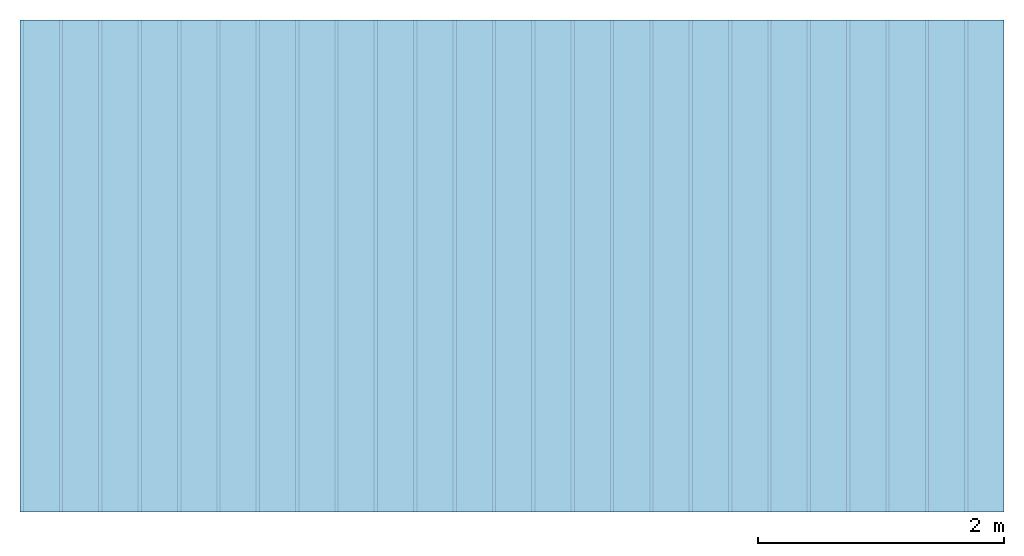
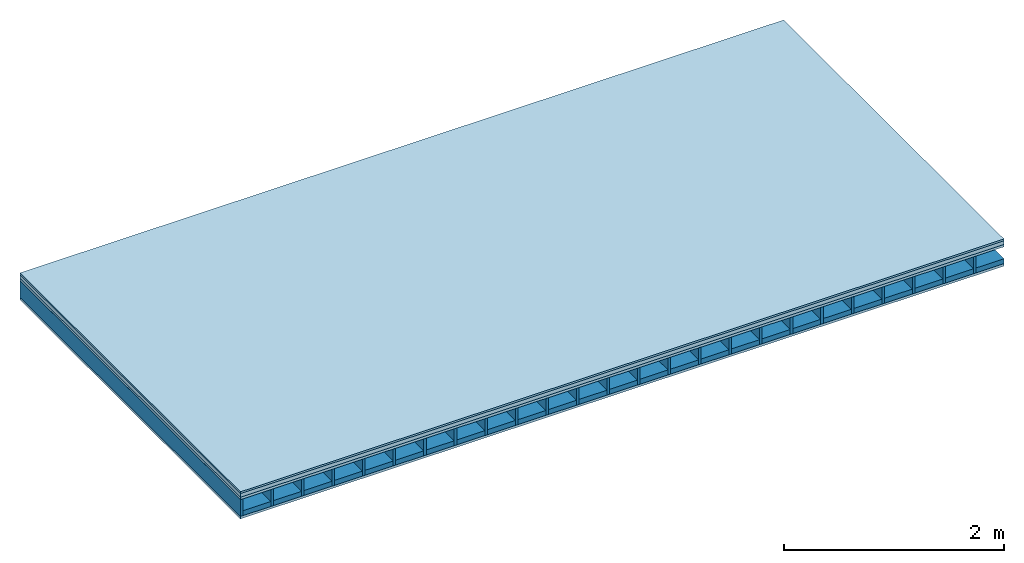
# One storey: 4 plates, 2 members, 1 element without a shape of its own.
"""IFC4 building model written with IfcOpenShell, lengths in metres."""

from ifc_helpers import new_model, si_unit, derived_unit, direction, frame, frame_2d, origin, origin_with_axes, place, context, project, spatial, rectangle, extrude, material, layer, layer_set, type_object, element, aggregate, save


model = new_model("IFC4")

# Units and contexts
plan_context = context("Plan", 3, precision=1e-05, world=origin(), true_north=direction((0.0, 1.0)))
model_context = context("Model", 3, precision=1e-05, world=origin(), true_north=direction((0.0, 1.0)))
ifc_project = project(units=[si_unit("LENGTHUNIT", "METRE"), derived_unit("SOUNDPRESSUREUNIT", [(si_unit("PRESSUREUNIT", "PASCAL", prefix="MICRO"), 0)]), si_unit("ENERGYUNIT", "JOULE", prefix="MEGA"), si_unit("MASSUNIT", "GRAM", prefix="KILO"), derived_unit("THERMALTRANSMITTANCEUNIT", [(si_unit("POWERUNIT", "WATT"), 1), (si_unit("AREAUNIT", "SQUARE_METRE"), -1), (si_unit("THERMODYNAMICTEMPERATUREUNIT", "KELVIN"), -1)]), derived_unit("AREADENSITYUNIT", [(si_unit("MASSUNIT", "GRAM", prefix="KILO"), 1), (si_unit("AREAUNIT", "SQUARE_METRE"), -1)]), derived_unit("USERDEFINED", [(si_unit("ENERGYUNIT", "JOULE", prefix="MEGA"), 1), (si_unit("AREAUNIT", "SQUARE_METRE"), -1)])], contexts=[plan_context, model_context])

# Site, building, storey
site = spatial("IfcSite", under=ifc_project)
building_placement = place(None, origin())
building = spatial("IfcBuilding", under=site, at=building_placement)
storey_placement = place(building_placement, origin())
storey = spatial("IfcBuildingStorey", under=building, at=storey_placement)

# Slab, members, plates
ifc_material_1 = material(Category="03.007")
ifc_layer_1 = layer(ifc_material_1, 0.02, Name="On-material")
ifc_material_2 = material(Name="internal", Category="10.009")
ifc_layer_2 = layer(ifc_material_2, 0.04, Name="Impact sound insulation")
ifc_material_3 = material(Name="3-layer board Spruce Nova Top", Category="07.001")
ifc_layer_3 = layer(ifc_material_3, 0.027, Name="Sub-floor")
ifc_material_4 = material(Name="Rigid, of the art")
ifc_layer_4 = layer(ifc_material_4, 0.0, Name="Bond")
ifc_layer_5 = layer(None, 0.186, Name="Supporting structure")
ifc_layer_6 = layer(ifc_material_4, 0.0, Name="Bond")
ifc_layer_7 = layer(ifc_material_3, 0.027, Name="Lower layer 1")
ifc_layer_set = layer_set([ifc_layer_1, ifc_layer_2, ifc_layer_3, ifc_layer_4, ifc_layer_5, ifc_layer_6, ifc_layer_7])
slab_type = type_object("IfcSlabType", Name="A0018", PredefinedType="NOTDEFINED", material=ifc_layer_set)
slab_placement = place(None, frame((0.0, 0.0, 0.0), z_axis=(0.0, 0.0, -1.0), x_axis=(1.0, 0.0, 0.0)))
slab = element("IfcSlab", 1, at=slab_placement, inside=storey, type_object=slab_type, material=ifc_layer_set, Name="Slab #1")
ifc_material_5 = material()
member_1_placement = place(slab_placement, origin())
member_1 = element("IfcMember", 2, at=member_1_placement, material=ifc_material_5, Name="Supporting structure", context=plan_context, shape_type="SweptSolid", body=[
    extrude(rectangle(XDim=0.027, YDim=0.186, at=frame_2d((0.0135, 0.093), x_axis=(1.0, 0.0))), frame((0.0, 4.0, 0.087), z_axis=(0.0, -1.0, 0.0), x_axis=(1.0, 0.0, 0.0)), (0.0, 0.0, 1.0), 4.0),
    extrude(rectangle(XDim=0.027, YDim=0.186, at=frame_2d((0.0135, 0.093), x_axis=(1.0, 0.0))), frame((0.32, 4.0, 0.087), z_axis=(0.0, -1.0, 0.0), x_axis=(1.0, 0.0, 0.0)), (0.0, 0.0, 1.0), 4.0),
    extrude(rectangle(XDim=0.027, YDim=0.186, at=frame_2d((0.0135, 0.093), x_axis=(1.0, 0.0))), frame((0.64, 4.0, 0.087), z_axis=(0.0, -1.0, 0.0), x_axis=(1.0, 0.0, 0.0)), (0.0, 0.0, 1.0), 4.0),
    extrude(rectangle(XDim=0.027, YDim=0.186, at=frame_2d((0.0135, 0.093), x_axis=(1.0, 0.0))), frame((0.96, 4.0, 0.087), z_axis=(0.0, -1.0, 0.0), x_axis=(1.0, 0.0, 0.0)), (0.0, 0.0, 1.0), 4.0),
    extrude(rectangle(XDim=0.027, YDim=0.186, at=frame_2d((0.0135, 0.093), x_axis=(1.0, 0.0))), frame((1.28, 4.0, 0.087), z_axis=(0.0, -1.0, 0.0), x_axis=(1.0, 0.0, 0.0)), (0.0, 0.0, 1.0), 4.0),
    extrude(rectangle(XDim=0.027, YDim=0.186, at=frame_2d((0.0135, 0.093), x_axis=(1.0, 0.0))), frame((1.6, 4.0, 0.087), z_axis=(0.0, -1.0, 0.0), x_axis=(1.0, 0.0, 0.0)), (0.0, 0.0, 1.0), 4.0),
    extrude(rectangle(XDim=0.027, YDim=0.186, at=frame_2d((0.0135, 0.093), x_axis=(1.0, 0.0))), frame((1.92, 4.0, 0.087), z_axis=(0.0, -1.0, 0.0), x_axis=(1.0, 0.0, 0.0)), (0.0, 0.0, 1.0), 4.0),
    extrude(rectangle(XDim=0.027, YDim=0.186, at=frame_2d((0.0135, 0.093), x_axis=(1.0, 0.0))), frame((2.24, 4.0, 0.087), z_axis=(0.0, -1.0, 0.0), x_axis=(1.0, 0.0, 0.0)), (0.0, 0.0, 1.0), 4.0),
    extrude(rectangle(XDim=0.027, YDim=0.186, at=frame_2d((0.0135, 0.093), x_axis=(1.0, 0.0))), frame((2.56, 4.0, 0.087), z_axis=(0.0, -1.0, 0.0), x_axis=(1.0, 0.0, 0.0)), (0.0, 0.0, 1.0), 4.0),
    extrude(rectangle(XDim=0.027, YDim=0.186, at=frame_2d((0.0135, 0.093), x_axis=(1.0, 0.0))), frame((2.88, 4.0, 0.087), z_axis=(0.0, -1.0, 0.0), x_axis=(1.0, 0.0, 0.0)), (0.0, 0.0, 1.0), 4.0),
    extrude(rectangle(XDim=0.027, YDim=0.186, at=frame_2d((0.0135, 0.093), x_axis=(1.0, 0.0))), frame((3.2, 4.0, 0.087), z_axis=(0.0, -1.0, 0.0), x_axis=(1.0, 0.0, 0.0)), (0.0, 0.0, 1.0), 4.0),
    extrude(rectangle(XDim=0.027, YDim=0.186, at=frame_2d((0.0135, 0.093), x_axis=(1.0, 0.0))), frame((3.52, 4.0, 0.087), z_axis=(0.0, -1.0, 0.0), x_axis=(1.0, 0.0, 0.0)), (0.0, 0.0, 1.0), 4.0),
    extrude(rectangle(XDim=0.027, YDim=0.186, at=frame_2d((0.0135, 0.093), x_axis=(1.0, 0.0))), frame((3.84, 4.0, 0.087), z_axis=(0.0, -1.0, 0.0), x_axis=(1.0, 0.0, 0.0)), (0.0, 0.0, 1.0), 4.0),
    extrude(rectangle(XDim=0.027, YDim=0.186, at=frame_2d((0.0135, 0.093), x_axis=(1.0, 0.0))), frame((4.16, 4.0, 0.087), z_axis=(0.0, -1.0, 0.0), x_axis=(1.0, 0.0, 0.0)), (0.0, 0.0, 1.0), 4.0),
    extrude(rectangle(XDim=0.027, YDim=0.186, at=frame_2d((0.0135, 0.093), x_axis=(1.0, 0.0))), frame((4.48, 4.0, 0.087), z_axis=(0.0, -1.0, 0.0), x_axis=(1.0, 0.0, 0.0)), (0.0, 0.0, 1.0), 4.0),
    extrude(rectangle(XDim=0.027, YDim=0.186, at=frame_2d((0.0135, 0.093), x_axis=(1.0, 0.0))), frame((4.8, 4.0, 0.087), z_axis=(0.0, -1.0, 0.0), x_axis=(1.0, 0.0, 0.0)), (0.0, 0.0, 1.0), 4.0),
    extrude(rectangle(XDim=0.027, YDim=0.186, at=frame_2d((0.0135, 0.093), x_axis=(1.0, 0.0))), frame((5.12, 4.0, 0.087), z_axis=(0.0, -1.0, 0.0), x_axis=(1.0, 0.0, 0.0)), (0.0, 0.0, 1.0), 4.0),
    extrude(rectangle(XDim=0.027, YDim=0.186, at=frame_2d((0.0135, 0.093), x_axis=(1.0, 0.0))), frame((5.44, 4.0, 0.087), z_axis=(0.0, -1.0, 0.0), x_axis=(1.0, 0.0, 0.0)), (0.0, 0.0, 1.0), 4.0),
    extrude(rectangle(XDim=0.027, YDim=0.186, at=frame_2d((0.0135, 0.093), x_axis=(1.0, 0.0))), frame((5.76, 4.0, 0.087), z_axis=(0.0, -1.0, 0.0), x_axis=(1.0, 0.0, 0.0)), (0.0, 0.0, 1.0), 4.0),
    extrude(rectangle(XDim=0.027, YDim=0.186, at=frame_2d((0.0135, 0.093), x_axis=(1.0, 0.0))), frame((6.08, 4.0, 0.087), z_axis=(0.0, -1.0, 0.0), x_axis=(1.0, 0.0, 0.0)), (0.0, 0.0, 1.0), 4.0),
    extrude(rectangle(XDim=0.027, YDim=0.186, at=frame_2d((0.0135, 0.093), x_axis=(1.0, 0.0))), frame((6.4, 4.0, 0.087), z_axis=(0.0, -1.0, 0.0), x_axis=(1.0, 0.0, 0.0)), (0.0, 0.0, 1.0), 4.0),
    extrude(rectangle(XDim=0.027, YDim=0.186, at=frame_2d((0.0135, 0.093), x_axis=(1.0, 0.0))), frame((6.72, 4.0, 0.087), z_axis=(0.0, -1.0, 0.0), x_axis=(1.0, 0.0, 0.0)), (0.0, 0.0, 1.0), 4.0),
    extrude(rectangle(XDim=0.027, YDim=0.186, at=frame_2d((0.0135, 0.093), x_axis=(1.0, 0.0))), frame((7.04, 4.0, 0.087), z_axis=(0.0, -1.0, 0.0), x_axis=(1.0, 0.0, 0.0)), (0.0, 0.0, 1.0), 4.0),
    extrude(rectangle(XDim=0.027, YDim=0.186, at=frame_2d((0.0135, 0.093), x_axis=(1.0, 0.0))), frame((7.36, 4.0, 0.087), z_axis=(0.0, -1.0, 0.0), x_axis=(1.0, 0.0, 0.0)), (0.0, 0.0, 1.0), 4.0),
    extrude(rectangle(XDim=0.027, YDim=0.186, at=frame_2d((0.0135, 0.093), x_axis=(1.0, 0.0))), frame((7.68, 4.0, 0.087), z_axis=(0.0, -1.0, 0.0), x_axis=(1.0, 0.0, 0.0)), (0.0, 0.0, 1.0), 4.0),
])
ifc_material_6 = material(Name="Gravel of lime 3-6 mm")
member_2_placement = place(slab_placement, origin())
member_2 = element("IfcMember", 3, at=member_2_placement, material=ifc_material_6, Name="in supporting structure", context=plan_context, shape_type="SweptSolid", body=[
    extrude(rectangle(XDim=0.293, YDim=0.0544, at=frame_2d((0.1465, 0.0272), x_axis=(1.0, 0.0))), frame((0.027, 4.0, 0.2186), z_axis=(0.0, -1.0, 0.0), x_axis=(1.0, 0.0, 0.0)), (0.0, 0.0, 1.0), 4.0),
    extrude(rectangle(XDim=0.293, YDim=0.0544, at=frame_2d((0.1465, 0.0272), x_axis=(1.0, 0.0))), frame((0.347, 4.0, 0.2186), z_axis=(0.0, -1.0, 0.0), x_axis=(1.0, 0.0, 0.0)), (0.0, 0.0, 1.0), 4.0),
    extrude(rectangle(XDim=0.293, YDim=0.0544, at=frame_2d((0.1465, 0.0272), x_axis=(1.0, 0.0))), frame((0.667, 4.0, 0.2186), z_axis=(0.0, -1.0, 0.0), x_axis=(1.0, 0.0, 0.0)), (0.0, 0.0, 1.0), 4.0),
    extrude(rectangle(XDim=0.293, YDim=0.0544, at=frame_2d((0.1465, 0.0272), x_axis=(1.0, 0.0))), frame((0.987, 4.0, 0.2186), z_axis=(0.0, -1.0, 0.0), x_axis=(1.0, 0.0, 0.0)), (0.0, 0.0, 1.0), 4.0),
    extrude(rectangle(XDim=0.293, YDim=0.0544, at=frame_2d((0.1465, 0.0272), x_axis=(1.0, 0.0))), frame((1.307, 4.0, 0.2186), z_axis=(0.0, -1.0, 0.0), x_axis=(1.0, 0.0, 0.0)), (0.0, 0.0, 1.0), 4.0),
    extrude(rectangle(XDim=0.293, YDim=0.0544, at=frame_2d((0.1465, 0.0272), x_axis=(1.0, 0.0))), frame((1.627, 4.0, 0.2186), z_axis=(0.0, -1.0, 0.0), x_axis=(1.0, 0.0, 0.0)), (0.0, 0.0, 1.0), 4.0),
    extrude(rectangle(XDim=0.293, YDim=0.0544, at=frame_2d((0.1465, 0.0272), x_axis=(1.0, 0.0))), frame((1.947, 4.0, 0.2186), z_axis=(0.0, -1.0, 0.0), x_axis=(1.0, 0.0, 0.0)), (0.0, 0.0, 1.0), 4.0),
    extrude(rectangle(XDim=0.293, YDim=0.0544, at=frame_2d((0.1465, 0.0272), x_axis=(1.0, 0.0))), frame((2.267, 4.0, 0.2186), z_axis=(0.0, -1.0, 0.0), x_axis=(1.0, 0.0, 0.0)), (0.0, 0.0, 1.0), 4.0),
    extrude(rectangle(XDim=0.293, YDim=0.0544, at=frame_2d((0.1465, 0.0272), x_axis=(1.0, 0.0))), frame((2.587, 4.0, 0.2186), z_axis=(0.0, -1.0, 0.0), x_axis=(1.0, 0.0, 0.0)), (0.0, 0.0, 1.0), 4.0),
    extrude(rectangle(XDim=0.293, YDim=0.0544, at=frame_2d((0.1465, 0.0272), x_axis=(1.0, 0.0))), frame((2.907, 4.0, 0.2186), z_axis=(0.0, -1.0, 0.0), x_axis=(1.0, 0.0, 0.0)), (0.0, 0.0, 1.0), 4.0),
    extrude(rectangle(XDim=0.293, YDim=0.0544, at=frame_2d((0.1465, 0.0272), x_axis=(1.0, 0.0))), frame((3.227, 4.0, 0.2186), z_axis=(0.0, -1.0, 0.0), x_axis=(1.0, 0.0, 0.0)), (0.0, 0.0, 1.0), 4.0),
    extrude(rectangle(XDim=0.293, YDim=0.0544, at=frame_2d((0.1465, 0.0272), x_axis=(1.0, 0.0))), frame((3.547, 4.0, 0.2186), z_axis=(0.0, -1.0, 0.0), x_axis=(1.0, 0.0, 0.0)), (0.0, 0.0, 1.0), 4.0),
    extrude(rectangle(XDim=0.293, YDim=0.0544, at=frame_2d((0.1465, 0.0272), x_axis=(1.0, 0.0))), frame((3.867, 4.0, 0.2186), z_axis=(0.0, -1.0, 0.0), x_axis=(1.0, 0.0, 0.0)), (0.0, 0.0, 1.0), 4.0),
    extrude(rectangle(XDim=0.293, YDim=0.0544, at=frame_2d((0.1465, 0.0272), x_axis=(1.0, 0.0))), frame((4.187, 4.0, 0.2186), z_axis=(0.0, -1.0, 0.0), x_axis=(1.0, 0.0, 0.0)), (0.0, 0.0, 1.0), 4.0),
    extrude(rectangle(XDim=0.293, YDim=0.0544, at=frame_2d((0.1465, 0.0272), x_axis=(1.0, 0.0))), frame((4.507, 4.0, 0.2186), z_axis=(0.0, -1.0, 0.0), x_axis=(1.0, 0.0, 0.0)), (0.0, 0.0, 1.0), 4.0),
    extrude(rectangle(XDim=0.293, YDim=0.0544, at=frame_2d((0.1465, 0.0272), x_axis=(1.0, 0.0))), frame((4.827, 4.0, 0.2186), z_axis=(0.0, -1.0, 0.0), x_axis=(1.0, 0.0, 0.0)), (0.0, 0.0, 1.0), 4.0),
    extrude(rectangle(XDim=0.293, YDim=0.0544, at=frame_2d((0.1465, 0.0272), x_axis=(1.0, 0.0))), frame((5.147, 4.0, 0.2186), z_axis=(0.0, -1.0, 0.0), x_axis=(1.0, 0.0, 0.0)), (0.0, 0.0, 1.0), 4.0),
    extrude(rectangle(XDim=0.293, YDim=0.0544, at=frame_2d((0.1465, 0.0272), x_axis=(1.0, 0.0))), frame((5.467, 4.0, 0.2186), z_axis=(0.0, -1.0, 0.0), x_axis=(1.0, 0.0, 0.0)), (0.0, 0.0, 1.0), 4.0),
    extrude(rectangle(XDim=0.293, YDim=0.0544, at=frame_2d((0.1465, 0.0272), x_axis=(1.0, 0.0))), frame((5.787, 4.0, 0.2186), z_axis=(0.0, -1.0, 0.0), x_axis=(1.0, 0.0, 0.0)), (0.0, 0.0, 1.0), 4.0),
    extrude(rectangle(XDim=0.293, YDim=0.0544, at=frame_2d((0.1465, 0.0272), x_axis=(1.0, 0.0))), frame((6.107, 4.0, 0.2186), z_axis=(0.0, -1.0, 0.0), x_axis=(1.0, 0.0, 0.0)), (0.0, 0.0, 1.0), 4.0),
    extrude(rectangle(XDim=0.293, YDim=0.0544, at=frame_2d((0.1465, 0.0272), x_axis=(1.0, 0.0))), frame((6.427, 4.0, 0.2186), z_axis=(0.0, -1.0, 0.0), x_axis=(1.0, 0.0, 0.0)), (0.0, 0.0, 1.0), 4.0),
    extrude(rectangle(XDim=0.293, YDim=0.0544, at=frame_2d((0.1465, 0.0272), x_axis=(1.0, 0.0))), frame((6.747, 4.0, 0.2186), z_axis=(0.0, -1.0, 0.0), x_axis=(1.0, 0.0, 0.0)), (0.0, 0.0, 1.0), 4.0),
    extrude(rectangle(XDim=0.293, YDim=0.0544, at=frame_2d((0.1465, 0.0272), x_axis=(1.0, 0.0))), frame((7.067, 4.0, 0.2186), z_axis=(0.0, -1.0, 0.0), x_axis=(1.0, 0.0, 0.0)), (0.0, 0.0, 1.0), 4.0),
    extrude(rectangle(XDim=0.293, YDim=0.0544, at=frame_2d((0.1465, 0.0272), x_axis=(1.0, 0.0))), frame((7.387, 4.0, 0.2186), z_axis=(0.0, -1.0, 0.0), x_axis=(1.0, 0.0, 0.0)), (0.0, 0.0, 1.0), 4.0),
    extrude(rectangle(XDim=0.293, YDim=0.0544, at=frame_2d((0.1465, 0.0272), x_axis=(1.0, 0.0))), frame((7.707, 4.0, 0.2186), z_axis=(0.0, -1.0, 0.0), x_axis=(1.0, 0.0, 0.0)), (0.0, 0.0, 1.0), 4.0),
])
plate_1_placement = place(slab_placement, origin())
plate_1 = element("IfcPlate", 4, at=plate_1_placement, material=ifc_material_1, Name="On-material", context=plan_context, shape_type="SweptSolid", body=[
    extrude(rectangle(XDim=8.0, YDim=4.0, at=frame_2d((4.0, 2.0), x_axis=(1.0, 0.0))), origin_with_axes(), (0.0, 0.0, 1.0), 0.02),
])
plate_2_placement = place(slab_placement, origin())
plate_2 = element("IfcPlate", 5, at=plate_2_placement, material=ifc_material_2, Name="Impact sound insulation", context=plan_context, shape_type="SweptSolid", body=[
    extrude(rectangle(XDim=8.0, YDim=4.0, at=frame_2d((4.0, 2.0), x_axis=(1.0, 0.0))), frame((0.0, 0.0, 0.02), z_axis=(0.0, 0.0, 1.0), x_axis=(1.0, 0.0, 0.0)), (0.0, 0.0, 1.0), 0.04),
])
plate_3_placement = place(slab_placement, origin())
plate_3 = element("IfcPlate", 6, at=plate_3_placement, material=ifc_material_3, Name="Sub-floor", context=plan_context, shape_type="SweptSolid", body=[
    extrude(rectangle(XDim=8.0, YDim=4.0, at=frame_2d((4.0, 2.0), x_axis=(1.0, 0.0))), frame((0.0, 0.0, 0.06), z_axis=(0.0, 0.0, 1.0), x_axis=(1.0, 0.0, 0.0)), (0.0, 0.0, 1.0), 0.027),
])
plate_4_placement = place(slab_placement, origin())
plate_4 = element("IfcPlate", 7, at=plate_4_placement, material=ifc_material_3, Name="Lower layer 1", context=plan_context, shape_type="SweptSolid", body=[
    extrude(rectangle(XDim=8.0, YDim=4.0, at=frame_2d((4.0, 2.0), x_axis=(1.0, 0.0))), frame((0.0, 0.0, 0.273), z_axis=(0.0, 0.0, 1.0), x_axis=(1.0, 0.0, 0.0)), (0.0, 0.0, 1.0), 0.027),
])
aggregate(slab, [plate_1, plate_2, plate_3, member_1, member_2, plate_4])

save(model, "model.ifc")
